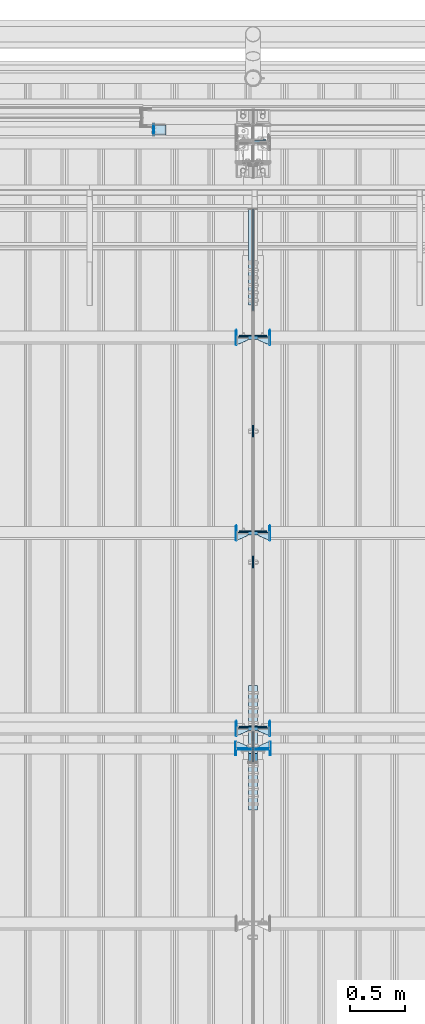
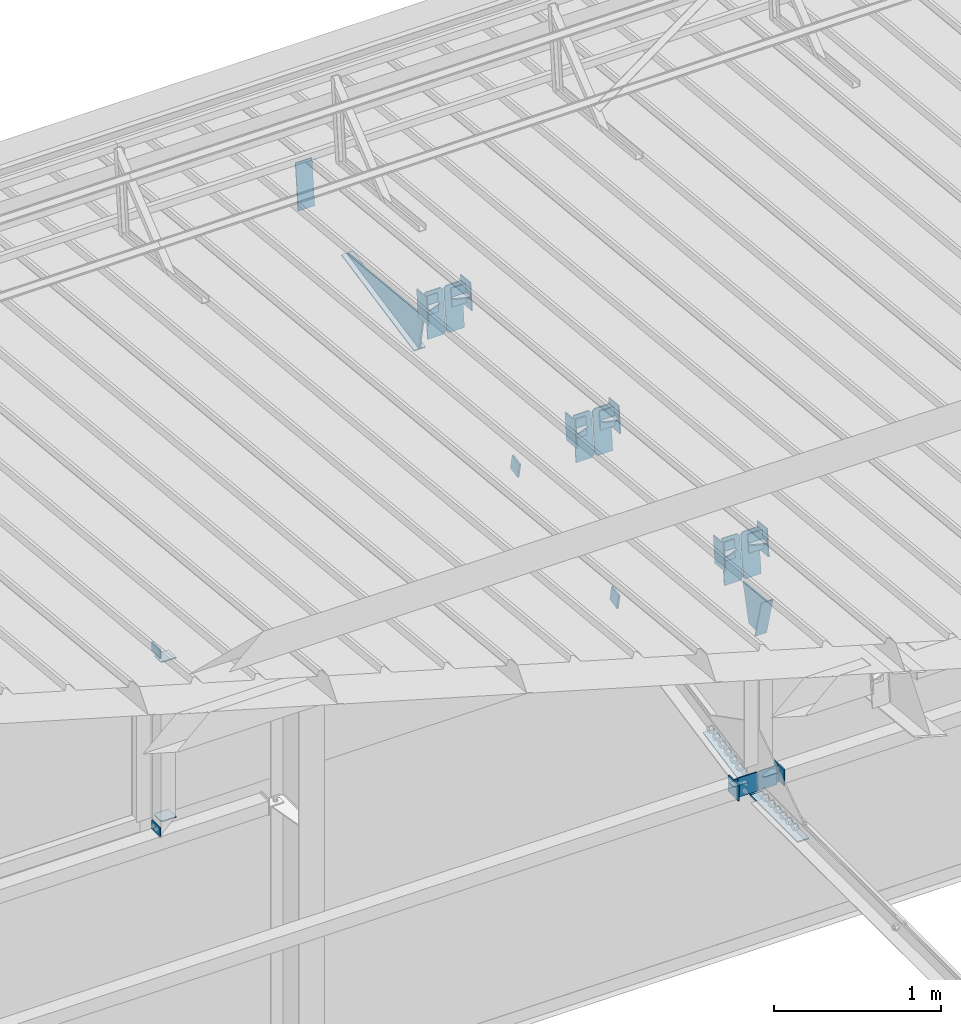
# One storey, part 159 of 709: 45 plates, 16 elements without a shape of their own.
"""IFC4 building model written with IfcOpenShell, lengths in millimetres."""

from ifc_helpers import new_model, si_unit, direction, frame, origin_with_axes, place, context, subcontext, project, spatial, line, indexed_curve, outline, extrude, material, element, aggregate, save


model = new_model("IFC4")

# Units and contexts
model_context = context("Model", 3, precision=0.2, world=origin_with_axes(), true_north=direction((0.0, 1.0)))
body_context = subcontext(model_context, "Body", "Model", "MODEL_VIEW")
ifc_project = project(units=[si_unit("LENGTHUNIT", "METRE", prefix="MILLI"), si_unit("AREAUNIT", "SQUARE_METRE"), si_unit("VOLUMEUNIT", "CUBIC_METRE"), si_unit("MASSUNIT", "GRAM", prefix="KILO"), si_unit("TIMEUNIT", "SECOND"), si_unit("PLANEANGLEUNIT", "RADIAN"), si_unit("SOLIDANGLEUNIT", "STERADIAN"), si_unit("THERMODYNAMICTEMPERATUREUNIT", "DEGREE_CELSIUS"), si_unit("LUMINOUSINTENSITYUNIT", "LUMEN")], contexts=[model_context])

# Site, building, storey
site_placement = place(None, origin_with_axes())
site = spatial("IfcSite", under=ifc_project, at=site_placement, CompositionType="ELEMENT")
building_placement = place(site_placement, origin_with_axes())
building = spatial("IfcBuilding", under=site, at=building_placement, Name="Undefined", CompositionType="ELEMENT")
storey_placement = place(building_placement, origin_with_axes())
storey = spatial("IfcBuildingStorey", under=building, at=storey_placement, Name="Undefined", CompositionType="ELEMENT", Elevation=0.0)

# Assembly, plate
assembly_1_placement = place(storey_placement, frame((34000.0, 21827.0, -200.0), z_axis=(-1.0, 0.0, 0.0), x_axis=(0.0, 0.0, 1.0)))
assembly_1 = element("IfcElementAssembly", 1, at=assembly_1_placement, inside=storey)
ifc_material = material(Name="C355-6", Category="STEEL")
plate_1_placement = place(assembly_1_placement, frame((7434.21546, 30.02526, -3.0), z_axis=(-0.099503719, 0.9950371902, 0.0), x_axis=(0.0, 0.0, -1.0)))
plate_1 = element("IfcPlate", 2, at=plate_1_placement, material=ifc_material, ObjectType="595", context=body_context, shape_type="SolidModel", body=[
    extrude(outline(indexed_curve([(0.0, 0.0), (114.0, 0.0), (114.0, 333.33554), (0.0, 333.33554)], segments=[line(1, 2, 3, 4, 1)])), frame((0.0, 0.0, 4.0), z_axis=(0.0, 0.0, 1.0), x_axis=(1.0, 0.0, 0.0)), (0.0, 0.0, -1.0), 8.0),
])
aggregate(assembly_1, [plate_1])

# Assembly, plates
assembly_2_placement = place(storey_placement, frame((34000.0, 21654.0, 7089.70002), z_axis=(-1.0, 0.0, 0.0), x_axis=(0.0, -0.9950371902, 0.099503719)))
assembly_2 = element("IfcElementAssembly", 3, at=assembly_2_placement, inside=storey)
plate_2_placement = place(assembly_2_placement, frame((1597.88359, 163.0, -127.0), z_axis=(1.0, 0.0, 0.0), x_axis=(0.0, 0.0, 1.0)))
plate_2 = element("IfcPlate", 4, at=plate_2_placement, material=ifc_material, ObjectType="585", context=body_context, shape_type="SolidModel", body=[
    extrude(outline(indexed_curve([(0.0, 0.0), (108.0, 0.0), (123.0, 15.0), (123.0, 311.0), (108.0, 326.0), (0.0, 326.0)], segments=[line(1, 2, 3, 4, 5, 6, 1)])), frame((0.0, 0.0, 4.0), z_axis=(0.0, 0.0, 1.0), x_axis=(1.0, 0.0, 0.0)), (0.0, 0.0, -1.0), 8.0),
])
plate_3_placement = place(assembly_2_placement, frame((1597.88359, 163.0, 127.0), z_axis=(-1.0, 0.0, 0.0), x_axis=(0.0, 0.0, -1.0)))
plate_3 = element("IfcPlate", 5, at=plate_3_placement, material=ifc_material, ObjectType="585", context=body_context, shape_type="SolidModel", body=[
    extrude(outline(indexed_curve([(0.0, 0.0), (108.0, 0.0), (123.0, 15.0), (123.0, 311.0), (108.0, 326.0), (0.0, 326.0)], segments=[line(1, 2, 3, 4, 5, 6, 1)])), frame((0.0, 0.0, 4.0), z_axis=(0.0, 0.0, 1.0), x_axis=(1.0, 0.0, 0.0)), (0.0, 0.0, -1.0), 8.0),
])
plate_4_placement = place(assembly_2_placement, frame((3383.44474, 163.0, -127.0), z_axis=(1.0, 0.0, 0.0), x_axis=(0.0, 0.0, 1.0)))
plate_4 = element("IfcPlate", 6, at=plate_4_placement, material=ifc_material, ObjectType="585", context=body_context, shape_type="SolidModel", body=[
    extrude(outline(indexed_curve([(0.0, 0.0), (108.0, 0.0), (123.0, 15.0), (123.0, 311.0), (108.0, 326.0), (0.0, 326.0)], segments=[line(1, 2, 3, 4, 5, 6, 1)])), frame((0.0, 0.0, 4.0), z_axis=(0.0, 0.0, 1.0), x_axis=(1.0, 0.0, 0.0)), (0.0, 0.0, -1.0), 8.0),
])
plate_5_placement = place(assembly_2_placement, frame((3383.44474, 163.0, 127.0), z_axis=(-1.0, 0.0, 0.0), x_axis=(0.0, 0.0, -1.0)))
plate_5 = element("IfcPlate", 7, at=plate_5_placement, material=ifc_material, ObjectType="585", context=body_context, shape_type="SolidModel", body=[
    extrude(outline(indexed_curve([(0.0, 0.0), (108.0, 0.0), (123.0, 15.0), (123.0, 311.0), (108.0, 326.0), (0.0, 326.0)], segments=[line(1, 2, 3, 4, 5, 6, 1)])), frame((0.0, 0.0, 4.0), z_axis=(0.0, 0.0, 1.0), x_axis=(1.0, 0.0, 0.0)), (0.0, 0.0, -1.0), 8.0),
])
plate_6_placement = place(assembly_2_placement, frame((5169.0059, 163.0, -127.0), z_axis=(1.0, 0.0, 0.0), x_axis=(0.0, 0.0, 1.0)))
plate_6 = element("IfcPlate", 8, at=plate_6_placement, material=ifc_material, ObjectType="585", context=body_context, shape_type="SolidModel", body=[
    extrude(outline(indexed_curve([(0.0, 0.0), (108.0, 0.0), (123.0, 15.0), (123.0, 311.0), (108.0, 326.0), (0.0, 326.0)], segments=[line(1, 2, 3, 4, 5, 6, 1)])), frame((0.0, 0.0, 4.0), z_axis=(0.0, 0.0, 1.0), x_axis=(1.0, 0.0, 0.0)), (0.0, 0.0, -1.0), 8.0),
])
plate_7_placement = place(assembly_2_placement, frame((5169.0059, 163.0, 127.0), z_axis=(-1.0, 0.0, 0.0), x_axis=(0.0, 0.0, -1.0)))
plate_7 = element("IfcPlate", 9, at=plate_7_placement, material=ifc_material, ObjectType="585", context=body_context, shape_type="SolidModel", body=[
    extrude(outline(indexed_curve([(0.0, 0.0), (108.0, 0.0), (123.0, 15.0), (123.0, 311.0), (108.0, 326.0), (0.0, 326.0)], segments=[line(1, 2, 3, 4, 5, 6, 1)])), frame((0.0, 0.0, 4.0), z_axis=(0.0, 0.0, 1.0), x_axis=(1.0, 0.0, 0.0)), (0.0, 0.0, -1.0), 8.0),
])
plate_8_placement = place(assembly_2_placement, frame((5462.44895, -172.70172, -40.0), z_axis=(-0.9353786626, 0.3536477874, 0.0), x_axis=(-0.3536477874, -0.9353786626, 0.0)))
plate_8 = element("IfcPlate", 10, at=plate_8_placement, material=ifc_material, ObjectType="443", context=body_context, shape_type="SolidModel", body=[
    extrude(outline(indexed_curve([(0.0, 0.0), (298.89845, 0.0), (298.89845, 80.0), (0.0, 80.0)], segments=[line(1, 2, 3, 4, 1)])), frame((0.0, 0.0, 4.0), z_axis=(0.0, 0.0, 1.0), x_axis=(1.0, 0.0, 0.0)), (0.0, 0.0, -1.0), 8.0),
])
plate_9_placement = place(assembly_2_placement, frame((5223.64782, -437.93487, 0.0), z_axis=(0.0, 0.0, -1.0), x_axis=(-0.1614213634, 0.9868855777, 0.0)))
plate_9 = element("IfcPlate", 11, at=plate_9_placement, material=ifc_material, ObjectType="442", context=body_context, shape_type="SolidModel", body=[
    extrude(outline(indexed_curve([(0.0, 0.0), (270.19115, 0.0), (225.20717, 275.01958), (-33.64648, 125.57036)], segments=[line(1, 2, 3, 4, 1)])), frame((0.0, 0.0, 6.0), z_axis=(0.0, 0.0, 1.0), x_axis=(1.0, 0.0, 0.0)), (0.0, 0.0, -1.0), 12.0),
])
plate_10_placement = place(assembly_2_placement, frame((1255.8048, -434.94249, -40.0), z_axis=(0.2927142719, 0.9561999556, 0.0), x_axis=(-0.9561999556, 0.2927142719, 0.0)))
plate_10 = element("IfcPlate", 12, at=plate_10_placement, material=ifc_material, ObjectType="450", context=body_context, shape_type="SolidModel", body=[
    extrude(outline(indexed_curve([(0.0, 0.0), (887.65935, 0.0), (887.65935, 80.0), (0.0, 80.0)], segments=[line(1, 2, 3, 4, 1)])), frame((0.0, 0.0, 4.0), z_axis=(0.0, 0.0, 1.0), x_axis=(1.0, 0.0, 0.0)), (0.0, 0.0, -1.0), 8.0),
])
plate_11_placement = place(assembly_2_placement, frame((1336.51563, -171.28713, 0.0), z_axis=(0.0, 0.0, 1.0), x_axis=(-1.0, 0.0, 0.0)))
plate_11 = element("IfcPlate", 13, at=plate_11_placement, material=ifc_material, ObjectType="449", context=body_context, shape_type="SolidModel", body=[
    extrude(outline(indexed_curve([(0.0, 0.0), (928.3198, 0.0), (79.53997, 259.83056)], segments=[line(1, 2, 3, 1)])), frame((0.0, 0.0, 6.0), z_axis=(0.0, 0.0, 1.0), x_axis=(1.0, 0.0, 0.0)), (0.0, 0.0, -1.0), 12.0),
])
aggregate(assembly_2, [plate_2, plate_3, plate_4, plate_5, plate_6, plate_7, plate_8, plate_9, plate_10, plate_11])

assembly_3_placement = place(storey_placement, frame((34000.0, 16331.38656, 5980.00002), z_axis=(-1.0, 0.0, 0.0), x_axis=(0.0, -1.0, 0.0)))
assembly_3 = element("IfcElementAssembly", 14, at=assembly_3_placement, inside=storey)
plate_12_placement = place(assembly_3_placement, frame((12.38656, 164.3, -134.0), z_axis=(1.0, 0.0, 0.0), x_axis=(0.0, 0.0, 1.0)))
plate_12 = element("IfcPlate", 15, at=plate_12_placement, material=ifc_material, ObjectType="558", context=body_context, shape_type="SolidModel", body=[
    extrude(outline(indexed_curve([(0.0, 0.0), (130.0, 0.0), (130.0, 140.0), (0.0, 140.0)], segments=[line(1, 2, 3, 4, 1)])), frame((0.0, 0.0, 4.0), z_axis=(0.0, 0.0, 1.0), x_axis=(1.0, 0.0, 0.0)), (0.0, 0.0, -1.0), 8.0),
])
plate_13_placement = place(assembly_3_placement, frame((12.38656, 164.3, 134.0), z_axis=(-1.0, 0.0, 0.0), x_axis=(0.0, 0.0, -1.0)))
plate_13 = element("IfcPlate", 16, at=plate_13_placement, material=ifc_material, ObjectType="558", context=body_context, shape_type="SolidModel", body=[
    extrude(outline(indexed_curve([(0.0, 0.0), (130.0, 0.0), (130.0, 140.0), (0.0, 140.0)], segments=[line(1, 2, 3, 4, 1)])), frame((0.0, 0.0, 4.0), z_axis=(0.0, 0.0, 1.0), x_axis=(1.0, 0.0, 0.0)), (0.0, 0.0, -1.0), 8.0),
])
plate_14_placement = place(assembly_3_placement, frame((-569.03779, 109.72834, -40.0), z_axis=(-0.1961161349, -0.9805806757, 0.0), x_axis=(0.9805806757, -0.1961161349, 0.0)))
plate_14 = element("IfcPlate", 17, at=plate_14_placement, material=ifc_material, ObjectType="447", context=body_context, shape_type="SolidModel", body=[
    extrude(outline(indexed_curve([(0.0, 0.0), (579.50696, 0.0), (579.50696, 80.0), (0.0, 80.0)], segments=[line(1, 2, 3, 4, 1)])), frame((0.0, 0.0, 4.0), z_axis=(0.0, 0.0, 1.0), x_axis=(1.0, 0.0, 0.0)), (0.0, 0.0, -1.0), 8.0),
])
plate_15_placement = place(assembly_3_placement, frame((564.38656, -4.0, -40.0), z_axis=(0.0, 1.0, 0.0), x_axis=(-1.0, 0.0, 0.0)))
plate_15 = element("IfcPlate", 18, at=plate_15_placement, material=ifc_material, ObjectType="446", context=body_context, shape_type="SolidModel", body=[
    extrude(outline(indexed_curve([(0.0, 0.0), (564.38656, 0.0), (564.38656, 80.0), (0.0, 80.0)], segments=[line(1, 2, 3, 4, 1)])), frame((0.0, 0.0, 4.0), z_axis=(0.0, 0.0, 1.0), x_axis=(1.0, 0.0, 0.0)), (0.0, 0.0, -1.0), 8.0),
])
aggregate(assembly_3, [plate_12, plate_13, plate_14, plate_15])

# Assembly, plate
assembly_4_placement = place(storey_placement, frame((34000.0, 19245.35924, 6685.17103), z_axis=(1.0, 0.0, 0.0), x_axis=(0.0, -0.9805806757, -0.1961161349)))
assembly_4 = element("IfcElementAssembly", 19, at=assembly_4_placement, inside=storey)
plate_16_placement = place(assembly_4_placement, origin_with_axes())
plate_16 = element("IfcPlate", 20, at=plate_16_placement, material=ifc_material, ObjectType="491", context=body_context, shape_type="SolidModel", body=[
    extrude(outline(indexed_curve([(0.0, 0.0), (90.0, 0.0), (90.0, 110.0), (0.0, 110.0)], segments=[line(1, 2, 3, 4, 1)])), frame((0.0, 0.0, 6.0), z_axis=(0.0, 0.0, 1.0), x_axis=(1.0, 0.0, 0.0)), (0.0, 0.0, -1.0), 12.0),
])
aggregate(assembly_4, [plate_16])

assembly_5_placement = place(storey_placement, frame((34000.0, 18055.82969, 6447.26512), z_axis=(1.0, 0.0, 0.0), x_axis=(0.0, -0.9805806757, -0.1961161349)))
assembly_5 = element("IfcElementAssembly", 21, at=assembly_5_placement, inside=storey)
plate_17_placement = place(assembly_5_placement, origin_with_axes())
plate_17 = element("IfcPlate", 22, at=plate_17_placement, material=ifc_material, ObjectType="491", context=body_context, shape_type="SolidModel", body=[
    extrude(outline(indexed_curve([(0.0, 0.0), (90.0, 0.0), (90.0, 110.0), (0.0, 110.0)], segments=[line(1, 2, 3, 4, 1)])), frame((0.0, 0.0, 6.0), z_axis=(0.0, 0.0, 1.0), x_axis=(1.0, 0.0, 0.0)), (0.0, 0.0, -1.0), 12.0),
])
aggregate(assembly_5, [plate_17])

assembly_6_placement = place(storey_placement, frame((34000.0, 21950.0, 2550.0), z_axis=(0.0, 0.0, -1.0), x_axis=(-1.0, 0.0, 0.0)))
assembly_6 = element("IfcElementAssembly", 23, at=assembly_6_placement, inside=storey)
plate_18_placement = place(assembly_6_placement, frame((904.0, 50.0, -50.0), z_axis=(-1.0, 0.0, 0.0), x_axis=(0.0, 0.0, -1.0)))
plate_18 = element("IfcPlate", 24, at=plate_18_placement, material=ifc_material, ObjectType="509", context=body_context, shape_type="SolidModel", body=[
    extrude(outline(indexed_curve([(0.0, 0.0), (65.0, 0.0), (65.0, 100.0), (0.0, 100.0)], segments=[line(1, 2, 3, 4, 1)])), frame((0.0, 0.0, 4.0), z_axis=(0.0, 0.0, 1.0), x_axis=(1.0, 0.0, 0.0)), (0.0, 0.0, -1.0), 8.0),
])
aggregate(assembly_6, [plate_18])

assembly_7_placement = place(storey_placement, frame((34000.0, 21950.0, 4020.0), z_axis=(0.0, 0.0, -1.0), x_axis=(-1.0, 0.0, 0.0)))
assembly_7 = element("IfcElementAssembly", 25, at=assembly_7_placement, inside=storey)
plate_19_placement = place(assembly_7_placement, frame((904.0, -50.0, 50.0), z_axis=(-1.0, 0.0, 0.0), x_axis=(0.0, 0.0, 1.0)))
plate_19 = element("IfcPlate", 26, at=plate_19_placement, material=ifc_material, ObjectType="509", context=body_context, shape_type="SolidModel", body=[
    extrude(outline(indexed_curve([(0.0, 0.0), (65.0, 0.0), (65.0, 100.0), (0.0, 100.0)], segments=[line(1, 2, 3, 4, 1)])), frame((0.0, 0.0, 4.0), z_axis=(0.0, 0.0, 1.0), x_axis=(1.0, 0.0, 0.0)), (0.0, 0.0, -1.0), 8.0),
])
aggregate(assembly_7, [plate_19])

# Assembly, plates
assembly_8_placement = place(storey_placement, frame((33150.0, 21950.0, 2600.0), z_axis=(-1.0, 0.0, 0.0), x_axis=(0.0, 0.0, 1.0)))
assembly_8 = element("IfcElementAssembly", 27, at=assembly_8_placement, inside=storey)
plate_20_placement = place(assembly_8_placement, frame((1267.0, 46.0, 46.0), z_axis=(1.0, 0.0, 0.0), x_axis=(0.0, -1.0, 0.0)))
plate_20 = element("IfcPlate", 28, at=plate_20_placement, material=ifc_material, ObjectType="510", context=body_context, shape_type="SolidModel", body=[
    extrude(outline(indexed_curve([(0.0, 10.0), (10.0, 0.0), (82.0, 0.0), (92.0, 10.0), (92.0, 104.0), (0.0, 104.0)], segments=[line(1, 2, 3, 4, 5, 6, 1)])), frame((0.0, 0.0, 4.0), z_axis=(0.0, 0.0, 1.0), x_axis=(1.0, 0.0, 0.0)), (0.0, 0.0, -1.0), 8.0),
])
plate_21_placement = place(assembly_8_placement, frame((103.0, -46.0, 46.0), z_axis=(-1.0, 0.0, 0.0), x_axis=(0.0, 1.0, 0.0)))
plate_21 = element("IfcPlate", 29, at=plate_21_placement, material=ifc_material, ObjectType="510", context=body_context, shape_type="SolidModel", body=[
    extrude(outline(indexed_curve([(0.0, 10.0), (10.0, 0.0), (82.0, 0.0), (92.0, 10.0), (92.0, 104.0), (0.0, 104.0)], segments=[line(1, 2, 3, 4, 5, 6, 1)])), frame((0.0, 0.0, 4.0), z_axis=(0.0, 0.0, 1.0), x_axis=(1.0, 0.0, 0.0)), (0.0, 0.0, -1.0), 8.0),
])
aggregate(assembly_8, [plate_20, plate_21])

assembly_9_placement = place(storey_placement, frame((28000.0, 16327.0, 6074.30002), z_axis=(0.0, -1.0, 0.0), x_axis=(1.0, 0.0, 0.0)))
assembly_9 = element("IfcElementAssembly", 30, at=assembly_9_placement, inside=storey)
plate_22_placement = place(assembly_9_placement, frame((5842.0, -60.0, 60.0), z_axis=(1.0, 0.0, 0.0), x_axis=(0.0, 0.0, -1.0)))
plate_22 = element("IfcPlate", 31, at=plate_22_placement, material=ifc_material, ObjectType="559", context=body_context, shape_type="SolidModel", body=[
    extrude(outline(indexed_curve([(0.0, 0.0), (120.0, 0.0), (120.0, 120.0), (0.0, 120.0)], segments=[line(1, 2, 3, 4, 1)])), frame((0.0, 0.0, 4.0), z_axis=(0.0, 0.0, 1.0), x_axis=(1.0, 0.0, 0.0)), (0.0, 0.0, -1.0), 8.0),
])
plate_23_placement = place(assembly_9_placement, frame((5946.0, -60.0, 0.0), z_axis=(0.0, 0.0, 1.0), x_axis=(0.0, 1.0, 0.0)))
plate_23 = element("IfcPlate", 32, at=plate_23_placement, material=ifc_material, ObjectType="560", context=body_context, shape_type="SolidModel", body=[
    extrude(outline(indexed_curve([(0.0, 0.0), (120.0, 0.0), (120.0, 100.0), (0.0, 100.0)], segments=[line(1, 2, 3, 4, 1)])), frame((0.0, 0.0, 4.0), z_axis=(0.0, 0.0, 1.0), x_axis=(1.0, 0.0, 0.0)), (0.0, 0.0, -1.0), 8.0),
])
plate_24_placement = place(assembly_9_placement, frame((5946.0, 0.0, -60.0), z_axis=(0.0, -1.0, 0.0), x_axis=(0.0, 0.0, 1.0)))
plate_24 = element("IfcPlate", 33, at=plate_24_placement, material=ifc_material, ObjectType="561", context=body_context, shape_type="SolidModel", body=[
    extrude(outline(indexed_curve([(0.0, 80.0), (36.0, 0.0), (56.0, 0.0), (56.0, 90.0), (46.0, 100.0), (0.0, 100.0)], segments=[line(1, 2, 3, 4, 5, 6, 1)])), frame((0.0, 0.0, 4.0), z_axis=(0.0, 0.0, 1.0), x_axis=(1.0, 0.0, 0.0)), (0.0, 0.0, -1.0), 8.0),
])
aggregate(assembly_9, [plate_22, plate_23, plate_24])

assembly_10_placement = place(storey_placement, frame((34000.0, 16327.0, 6074.30002), z_axis=(0.0, -1.0, 0.0), x_axis=(1.0, 0.0, 0.0)))
assembly_10 = element("IfcElementAssembly", 34, at=assembly_10_placement, inside=storey)
plate_25_placement = place(assembly_10_placement, frame((158.0, 60.0, 60.0), z_axis=(-1.0, 0.0, 0.0), x_axis=(0.0, 0.0, -1.0)))
plate_25 = element("IfcPlate", 35, at=plate_25_placement, material=ifc_material, ObjectType="559", context=body_context, shape_type="SolidModel", body=[
    extrude(outline(indexed_curve([(0.0, 0.0), (120.0, 0.0), (120.0, 120.0), (0.0, 120.0)], segments=[line(1, 2, 3, 4, 1)])), frame((0.0, 0.0, 4.0), z_axis=(0.0, 0.0, 1.0), x_axis=(1.0, 0.0, 0.0)), (0.0, 0.0, -1.0), 8.0),
])
plate_26_placement = place(assembly_10_placement, frame((54.0, 0.0, -60.0), z_axis=(0.0, 1.0, 0.0), x_axis=(0.0, 0.0, 1.0)))
plate_26 = element("IfcPlate", 36, at=plate_26_placement, material=ifc_material, ObjectType="561", context=body_context, shape_type="SolidModel", body=[
    extrude(outline(indexed_curve([(0.0, 80.0), (36.0, 0.0), (56.0, 0.0), (56.0, 90.0), (46.0, 100.0), (0.0, 100.0)], segments=[line(1, 2, 3, 4, 5, 6, 1)])), frame((0.0, 0.0, 4.0), z_axis=(0.0, 0.0, 1.0), x_axis=(1.0, 0.0, 0.0)), (0.0, 0.0, -1.0), 8.0),
])
plate_27_placement = place(assembly_10_placement, frame((54.0, 60.0, 0.0), z_axis=(0.0, 0.0, 1.0), x_axis=(0.0, -1.0, 0.0)))
plate_27 = element("IfcPlate", 37, at=plate_27_placement, material=ifc_material, ObjectType="560", context=body_context, shape_type="SolidModel", body=[
    extrude(outline(indexed_curve([(0.0, 0.0), (120.0, 0.0), (120.0, 100.0), (0.0, 100.0)], segments=[line(1, 2, 3, 4, 1)])), frame((0.0, 0.0, 4.0), z_axis=(0.0, 0.0, 1.0), x_axis=(1.0, 0.0, 0.0)), (0.0, 0.0, -1.0), 8.0),
])
aggregate(assembly_10, [plate_25, plate_26, plate_27])

assembly_11_placement = place(storey_placement, frame((34000.0, 16509.95037, 7677.46908), z_axis=(0.0, -0.9950371902, 0.099503719), x_axis=(-1.0, 0.0, 0.0)))
assembly_11 = element("IfcElementAssembly", 38, at=assembly_11_placement, inside=storey)
plate_28_placement = place(assembly_11_placement, frame((47.0, 0.0, 60.0), z_axis=(0.0, 1.0, 0.0), x_axis=(1.0, 0.0, 0.0)))
plate_28 = element("IfcPlate", 39, at=plate_28_placement, material=ifc_material, ObjectType="588", context=body_context, shape_type="SolidModel", body=[
    extrude(outline(indexed_curve([(0.0, 36.0), (80.0, 0.0), (100.0, 0.0), (100.0, 56.0), (0.0, 56.0)], segments=[line(1, 2, 3, 4, 5, 1)])), frame((0.0, 0.0, 4.0), z_axis=(0.0, 0.0, 1.0), x_axis=(1.0, 0.0, 0.0)), (0.0, 0.0, -1.0), 8.0),
])
plate_29_placement = place(assembly_11_placement, frame((151.0, -98.0, -60.0), z_axis=(-1.0, 0.0, 0.0), x_axis=(0.0, 0.0, 1.0)))
plate_29 = element("IfcPlate", 40, at=plate_29_placement, material=ifc_material, ObjectType="586", context=body_context, shape_type="SolidModel", body=[
    extrude(outline(indexed_curve([(0.0, 0.0), (120.0, 0.0), (120.0, 196.0), (0.0, 196.0)], segments=[line(1, 2, 3, 4, 1)])), frame((0.0, 0.0, 4.0), z_axis=(0.0, 0.0, 1.0), x_axis=(1.0, 0.0, 0.0)), (0.0, 0.0, -1.0), 8.0),
])
plate_30_placement = place(assembly_11_placement, frame((47.0, -65.0, 0.0), z_axis=(0.0, 0.0, 1.0), x_axis=(1.0, 0.0, 0.0)))
plate_30 = element("IfcPlate", 41, at=plate_30_placement, material=ifc_material, ObjectType="587", context=body_context, shape_type="SolidModel", body=[
    extrude(outline(indexed_curve([(0.0, 0.0), (100.0, 0.0), (100.0, 130.0), (0.0, 130.0)], segments=[line(1, 2, 3, 4, 1)])), frame((0.0, 0.0, 4.0), z_axis=(0.0, 0.0, 1.0), x_axis=(1.0, 0.0, 0.0)), (0.0, 0.0, -1.0), 8.0),
])
aggregate(assembly_11, [plate_28, plate_29, plate_30])

assembly_12_placement = place(storey_placement, frame((34000.0, 18286.65012, 7499.7991), z_axis=(0.0, -0.9950371902, 0.099503719), x_axis=(-1.0, 0.0, 0.0)))
assembly_12 = element("IfcElementAssembly", 42, at=assembly_12_placement, inside=storey)
plate_31_placement = place(assembly_12_placement, frame((47.0, -65.0, 0.0), z_axis=(0.0, 0.0, 1.0), x_axis=(1.0, 0.0, 0.0)))
plate_31 = element("IfcPlate", 43, at=plate_31_placement, material=ifc_material, ObjectType="587", context=body_context, shape_type="SolidModel", body=[
    extrude(outline(indexed_curve([(0.0, 0.0), (100.0, 0.0), (100.0, 130.0), (0.0, 130.0)], segments=[line(1, 2, 3, 4, 1)])), frame((0.0, 0.0, 4.0), z_axis=(0.0, 0.0, 1.0), x_axis=(1.0, 0.0, 0.0)), (0.0, 0.0, -1.0), 8.0),
])
plate_32_placement = place(assembly_12_placement, frame((151.0, -98.0, -60.0), z_axis=(-1.0, 0.0, 0.0), x_axis=(0.0, 0.0, 1.0)))
plate_32 = element("IfcPlate", 44, at=plate_32_placement, material=ifc_material, ObjectType="586", context=body_context, shape_type="SolidModel", body=[
    extrude(outline(indexed_curve([(0.0, 0.0), (120.0, 0.0), (120.0, 196.0), (0.0, 196.0)], segments=[line(1, 2, 3, 4, 1)])), frame((0.0, 0.0, 4.0), z_axis=(0.0, 0.0, 1.0), x_axis=(1.0, 0.0, 0.0)), (0.0, 0.0, -1.0), 8.0),
])
plate_33_placement = place(assembly_12_placement, frame((47.0, 0.0, 60.0), z_axis=(0.0, 1.0, 0.0), x_axis=(1.0, 0.0, 0.0)))
plate_33 = element("IfcPlate", 45, at=plate_33_placement, material=ifc_material, ObjectType="588", context=body_context, shape_type="SolidModel", body=[
    extrude(outline(indexed_curve([(0.0, 36.0), (80.0, 0.0), (100.0, 0.0), (100.0, 56.0), (0.0, 56.0)], segments=[line(1, 2, 3, 4, 5, 1)])), frame((0.0, 0.0, 4.0), z_axis=(0.0, 0.0, 1.0), x_axis=(1.0, 0.0, 0.0)), (0.0, 0.0, -1.0), 8.0),
])
aggregate(assembly_12, [plate_31, plate_32, plate_33])

assembly_13_placement = place(storey_placement, frame((34000.0, 20063.34988, 7322.12913), z_axis=(0.0, -0.9950371902, 0.099503719), x_axis=(-1.0, 0.0, 0.0)))
assembly_13 = element("IfcElementAssembly", 46, at=assembly_13_placement, inside=storey)
plate_34_placement = place(assembly_13_placement, frame((47.0, 0.0, 60.0), z_axis=(0.0, 1.0, 0.0), x_axis=(1.0, 0.0, 0.0)))
plate_34 = element("IfcPlate", 47, at=plate_34_placement, material=ifc_material, ObjectType="588", context=body_context, shape_type="SolidModel", body=[
    extrude(outline(indexed_curve([(0.0, 36.0), (80.0, 0.0), (100.0, 0.0), (100.0, 56.0), (0.0, 56.0)], segments=[line(1, 2, 3, 4, 5, 1)])), frame((0.0, 0.0, 4.0), z_axis=(0.0, 0.0, 1.0), x_axis=(1.0, 0.0, 0.0)), (0.0, 0.0, -1.0), 8.0),
])
plate_35_placement = place(assembly_13_placement, frame((47.0, -65.0, 0.0), z_axis=(0.0, 0.0, 1.0), x_axis=(1.0, 0.0, 0.0)))
plate_35 = element("IfcPlate", 48, at=plate_35_placement, material=ifc_material, ObjectType="587", context=body_context, shape_type="SolidModel", body=[
    extrude(outline(indexed_curve([(0.0, 0.0), (100.0, 0.0), (100.0, 130.0), (0.0, 130.0)], segments=[line(1, 2, 3, 4, 1)])), frame((0.0, 0.0, 4.0), z_axis=(0.0, 0.0, 1.0), x_axis=(1.0, 0.0, 0.0)), (0.0, 0.0, -1.0), 8.0),
])
plate_36_placement = place(assembly_13_placement, frame((151.0, -98.0, -60.0), z_axis=(-1.0, 0.0, 0.0), x_axis=(0.0, 0.0, 1.0)))
plate_36 = element("IfcPlate", 49, at=plate_36_placement, material=ifc_material, ObjectType="586", context=body_context, shape_type="SolidModel", body=[
    extrude(outline(indexed_curve([(0.0, 0.0), (120.0, 0.0), (120.0, 196.0), (0.0, 196.0)], segments=[line(1, 2, 3, 4, 1)])), frame((0.0, 0.0, 4.0), z_axis=(0.0, 0.0, 1.0), x_axis=(1.0, 0.0, 0.0)), (0.0, 0.0, -1.0), 8.0),
])
aggregate(assembly_13, [plate_34, plate_35, plate_36])

assembly_14_placement = place(storey_placement, frame((40000.0, 16509.95037, 7677.46908), z_axis=(0.0, -0.9950371902, 0.099503719), x_axis=(-1.0, 0.0, 0.0)))
assembly_14 = element("IfcElementAssembly", 50, at=assembly_14_placement, inside=storey)
plate_37_placement = place(assembly_14_placement, frame((5953.0, 65.0, 0.0), z_axis=(0.0, 0.0, 1.0), x_axis=(-1.0, 0.0, 0.0)))
plate_37 = element("IfcPlate", 51, at=plate_37_placement, material=ifc_material, ObjectType="587", context=body_context, shape_type="SolidModel", body=[
    extrude(outline(indexed_curve([(0.0, 0.0), (100.0, 0.0), (100.0, 130.0), (0.0, 130.0)], segments=[line(1, 2, 3, 4, 1)])), frame((0.0, 0.0, 4.0), z_axis=(0.0, 0.0, 1.0), x_axis=(1.0, 0.0, 0.0)), (0.0, 0.0, -1.0), 8.0),
])
plate_38_placement = place(assembly_14_placement, frame((5953.0, 0.0, 60.0), z_axis=(0.0, -1.0, 0.0), x_axis=(-1.0, 0.0, 0.0)))
plate_38 = element("IfcPlate", 52, at=plate_38_placement, material=ifc_material, ObjectType="588", context=body_context, shape_type="SolidModel", body=[
    extrude(outline(indexed_curve([(0.0, 36.0), (80.0, 0.0), (100.0, 0.0), (100.0, 56.0), (0.0, 56.0)], segments=[line(1, 2, 3, 4, 5, 1)])), frame((0.0, 0.0, 4.0), z_axis=(0.0, 0.0, 1.0), x_axis=(1.0, 0.0, 0.0)), (0.0, 0.0, -1.0), 8.0),
])
plate_39_placement = place(assembly_14_placement, frame((5849.0, -98.0, 60.0), z_axis=(1.0, 0.0, 0.0), x_axis=(0.0, 0.0, -1.0)))
plate_39 = element("IfcPlate", 53, at=plate_39_placement, material=ifc_material, ObjectType="586", context=body_context, shape_type="SolidModel", body=[
    extrude(outline(indexed_curve([(0.0, 0.0), (120.0, 0.0), (120.0, 196.0), (0.0, 196.0)], segments=[line(1, 2, 3, 4, 1)])), frame((0.0, 0.0, 4.0), z_axis=(0.0, 0.0, 1.0), x_axis=(1.0, 0.0, 0.0)), (0.0, 0.0, -1.0), 8.0),
])
aggregate(assembly_14, [plate_37, plate_38, plate_39])

assembly_15_placement = place(storey_placement, frame((40000.0, 18286.65012, 7499.7991), z_axis=(0.0, -0.9950371902, 0.099503719), x_axis=(-1.0, 0.0, 0.0)))
assembly_15 = element("IfcElementAssembly", 54, at=assembly_15_placement, inside=storey)
plate_40_placement = place(assembly_15_placement, frame((5953.0, 0.0, 60.0), z_axis=(0.0, -1.0, 0.0), x_axis=(-1.0, 0.0, 0.0)))
plate_40 = element("IfcPlate", 55, at=plate_40_placement, material=ifc_material, ObjectType="588", context=body_context, shape_type="SolidModel", body=[
    extrude(outline(indexed_curve([(0.0, 36.0), (80.0, 0.0), (100.0, 0.0), (100.0, 56.0), (0.0, 56.0)], segments=[line(1, 2, 3, 4, 5, 1)])), frame((0.0, 0.0, 4.0), z_axis=(0.0, 0.0, 1.0), x_axis=(1.0, 0.0, 0.0)), (0.0, 0.0, -1.0), 8.0),
])
plate_41_placement = place(assembly_15_placement, frame((5849.0, -98.0, 60.0), z_axis=(1.0, 0.0, 0.0), x_axis=(0.0, 0.0, -1.0)))
plate_41 = element("IfcPlate", 56, at=plate_41_placement, material=ifc_material, ObjectType="586", context=body_context, shape_type="SolidModel", body=[
    extrude(outline(indexed_curve([(0.0, 0.0), (120.0, 0.0), (120.0, 196.0), (0.0, 196.0)], segments=[line(1, 2, 3, 4, 1)])), frame((0.0, 0.0, 4.0), z_axis=(0.0, 0.0, 1.0), x_axis=(1.0, 0.0, 0.0)), (0.0, 0.0, -1.0), 8.0),
])
plate_42_placement = place(assembly_15_placement, frame((5953.0, 65.0, 0.0), z_axis=(0.0, 0.0, 1.0), x_axis=(-1.0, 0.0, 0.0)))
plate_42 = element("IfcPlate", 57, at=plate_42_placement, material=ifc_material, ObjectType="587", context=body_context, shape_type="SolidModel", body=[
    extrude(outline(indexed_curve([(0.0, 0.0), (100.0, 0.0), (100.0, 130.0), (0.0, 130.0)], segments=[line(1, 2, 3, 4, 1)])), frame((0.0, 0.0, 4.0), z_axis=(0.0, 0.0, 1.0), x_axis=(1.0, 0.0, 0.0)), (0.0, 0.0, -1.0), 8.0),
])
aggregate(assembly_15, [plate_40, plate_41, plate_42])

assembly_16_placement = place(storey_placement, frame((40000.0, 20063.34988, 7322.12913), z_axis=(0.0, -0.9950371902, 0.099503719), x_axis=(-1.0, 0.0, 0.0)))
assembly_16 = element("IfcElementAssembly", 58, at=assembly_16_placement, inside=storey)
plate_43_placement = place(assembly_16_placement, frame((5953.0, 0.0, 60.0), z_axis=(0.0, -1.0, 0.0), x_axis=(-1.0, 0.0, 0.0)))
plate_43 = element("IfcPlate", 59, at=plate_43_placement, material=ifc_material, ObjectType="588", context=body_context, shape_type="SolidModel", body=[
    extrude(outline(indexed_curve([(0.0, 36.0), (80.0, 0.0), (100.0, 0.0), (100.0, 56.0), (0.0, 56.0)], segments=[line(1, 2, 3, 4, 5, 1)])), frame((0.0, 0.0, 4.0), z_axis=(0.0, 0.0, 1.0), x_axis=(1.0, 0.0, 0.0)), (0.0, 0.0, -1.0), 8.0),
])
plate_44_placement = place(assembly_16_placement, frame((5953.0, 65.0, 0.0), z_axis=(0.0, 0.0, 1.0), x_axis=(-1.0, 0.0, 0.0)))
plate_44 = element("IfcPlate", 60, at=plate_44_placement, material=ifc_material, ObjectType="587", context=body_context, shape_type="SolidModel", body=[
    extrude(outline(indexed_curve([(0.0, 0.0), (100.0, 0.0), (100.0, 130.0), (0.0, 130.0)], segments=[line(1, 2, 3, 4, 1)])), frame((0.0, 0.0, 4.0), z_axis=(0.0, 0.0, 1.0), x_axis=(1.0, 0.0, 0.0)), (0.0, 0.0, -1.0), 8.0),
])
plate_45_placement = place(assembly_16_placement, frame((5849.0, -98.0, 60.0), z_axis=(1.0, 0.0, 0.0), x_axis=(0.0, 0.0, -1.0)))
plate_45 = element("IfcPlate", 61, at=plate_45_placement, material=ifc_material, ObjectType="586", context=body_context, shape_type="SolidModel", body=[
    extrude(outline(indexed_curve([(0.0, 0.0), (120.0, 0.0), (120.0, 196.0), (0.0, 196.0)], segments=[line(1, 2, 3, 4, 1)])), frame((0.0, 0.0, 4.0), z_axis=(0.0, 0.0, 1.0), x_axis=(1.0, 0.0, 0.0)), (0.0, 0.0, -1.0), 8.0),
])
aggregate(assembly_16, [plate_43, plate_44, plate_45])

save(model, "model.ifc")
